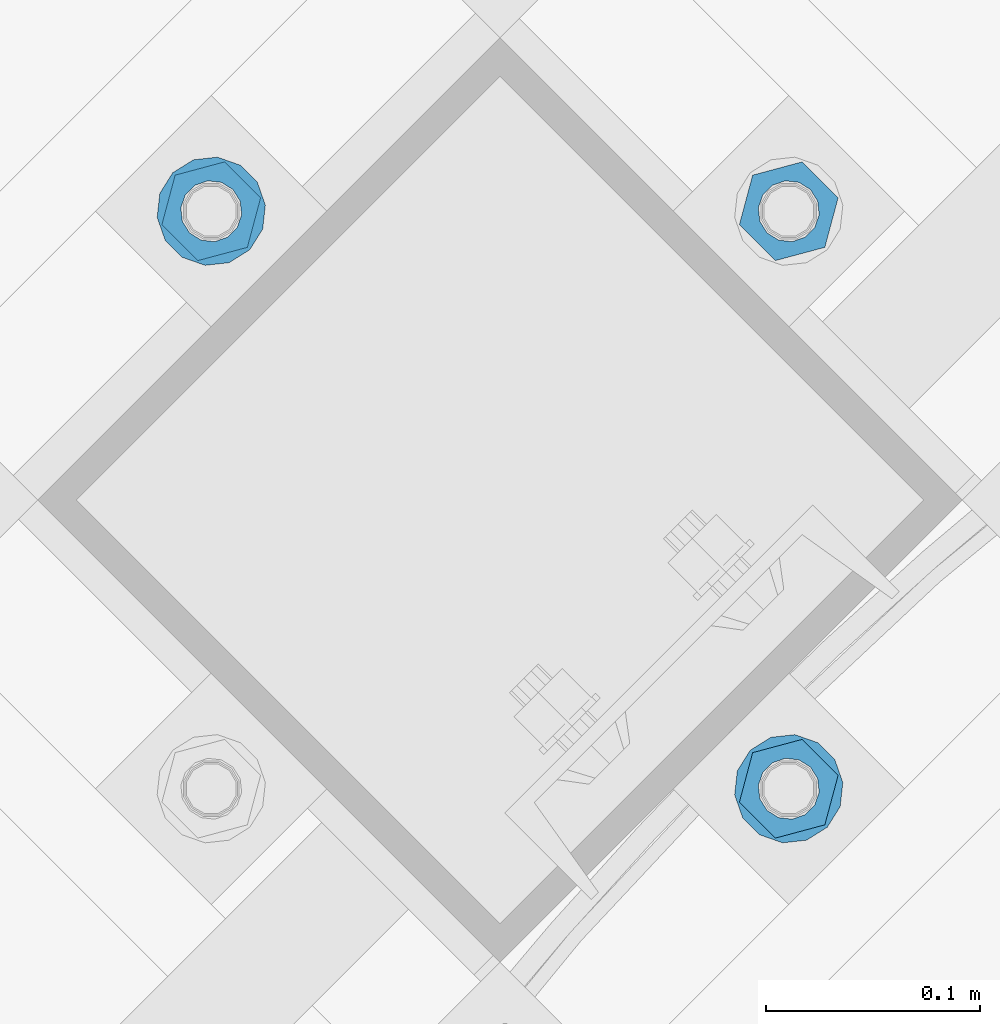
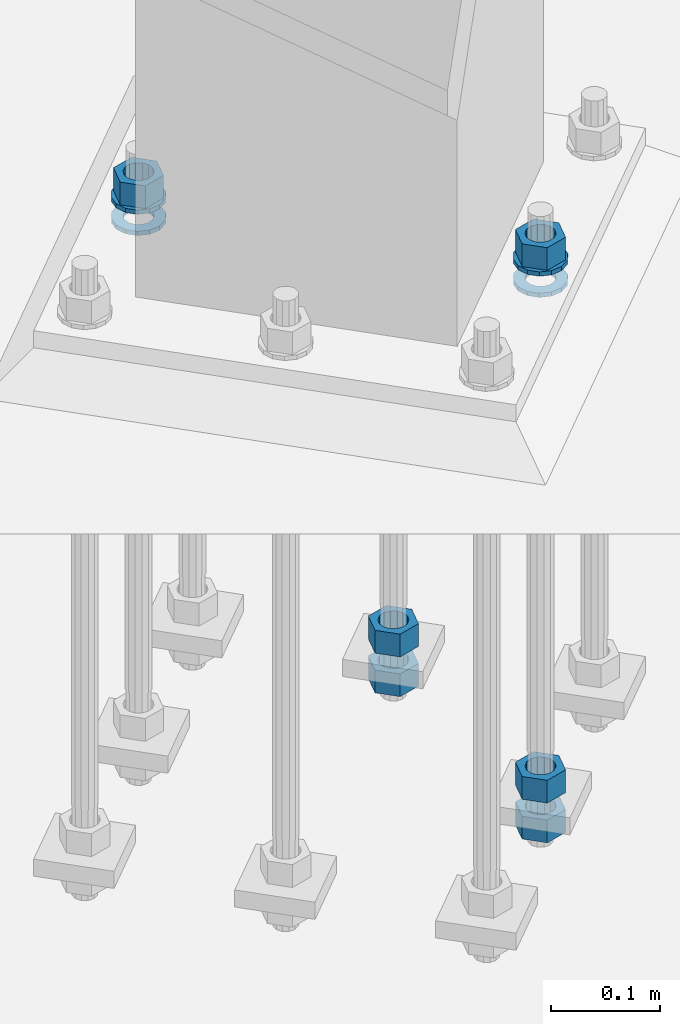
# One storey, part 871 of 1876: 10 columns, 1 element without a shape of its own.
"""IFC2X3 building model written with IfcOpenShell, lengths in millimetres."""

import ifcopenshell
import ifcopenshell.guid

model = None  # the IFC model being written
_history = None  # IfcOwnerHistory: only IFC2X3 demands one
_inside = {}  # id of a spatial element -> (the spatial element, [elements in it])
_under = {}  # id of a project, library or spatial element -> (it, [spatial elements below it])
_declared = {}  # id of a project -> (the project, [libraries it declares])
_typed = {}  # id of a type object -> (the type object, [elements of that type])
_made_of = {}  # id of a material, layer set ... -> (it, [elements and type objects made of it])


def new_model(schema):
    """Start an empty IFC model of exactly this schema.

    Asked for "IFC4X3", IfcOpenShell would pick the latest addendum, in which some entities
    have other attributes; the version numbers below select the first issue.
    IFC2X3 requires an IfcOwnerHistory on every rooted entity: one is made here for all.
    """
    global model, _history
    if schema == "IFC4X3":
        model = ifcopenshell.file(schema_version=(4, 3, 0, 0))
    else:
        model = ifcopenshell.file(schema=schema)
    _inside.clear()
    _under.clear()
    _declared.clear()
    _typed.clear()
    _made_of.clear()
    _history = None
    if model.schema == "IFC2X3":
        org = make("IfcOrganization", Name="unknown")
        user = make(
            "IfcPersonAndOrganization",
            ThePerson=make("IfcPerson", FamilyName="unknown"),
            TheOrganization=org,
        )
        app = make(
            "IfcApplication",
            ApplicationDeveloper=org,
            Version="unknown",
            ApplicationFullName="unknown",
            ApplicationIdentifier="unknown",
        )
        _history = make(
            "IfcOwnerHistory",
            OwningUser=user,
            OwningApplication=app,
            ChangeAction="ADDED",
            CreationDate=0,
        )
    return model


def make(cls, **values):
    """One entity of the class cls with the attributes given. An attribute that is None is left unset."""
    return model.create_entity(
        cls, **{name: value for name, value in values.items() if value is not None}
    )


def rooted(cls, **values):
    """An entity with a GlobalId (a new one), such as an element, a storey or a relation."""
    return make(cls, GlobalId=ifcopenshell.guid.new(), OwnerHistory=_history, **values)


def si_unit(unit_type, name, prefix=None):
    """IfcSIUnit, for example si_unit("LENGTHUNIT", "METRE", prefix="MILLI")."""
    return make("IfcSIUnit", UnitType=unit_type, Prefix=prefix, Name=name)


def assignment(units):
    """IfcUnitAssignment: the units of a project."""
    return None if units is None else make("IfcUnitAssignment", Units=units)


def point(xyz):
    """IfcCartesianPoint."""
    return None if xyz is None else make("IfcCartesianPoint", Coordinates=xyz)


def direction(xyz):
    """IfcDirection."""
    return None if xyz is None else make("IfcDirection", DirectionRatios=xyz)


def frame(location, z_axis=None, x_axis=None):
    """IfcAxis2Placement3D, a coordinate frame: its origin and axes. An axis left out is left unset."""
    return make(
        "IfcAxis2Placement3D",
        Location=point(location),
        Axis=direction(z_axis),
        RefDirection=direction(x_axis),
    )


def origin_with_axes():
    """The frame at (0, 0, 0) with the z axis (0, 0, 1) and the x axis (1, 0, 0) written out."""
    return frame((0.0, 0.0, 0.0), z_axis=(0.0, 0.0, 1.0), x_axis=(1.0, 0.0, 0.0))


def place(relative_to, where):
    """IfcLocalPlacement: puts the frame where relative to a parent placement (None: the world)."""
    return make(
        "IfcLocalPlacement", PlacementRelTo=relative_to, RelativePlacement=where
    )


def context(
    kind, dimensions, precision=None, world=None, true_north=None, identifier=None
):
    """IfcGeometricRepresentationContext, for example the 3D "Model" context."""
    return make(
        "IfcGeometricRepresentationContext",
        ContextIdentifier=identifier,
        ContextType=kind,
        CoordinateSpaceDimension=dimensions,
        Precision=precision,
        WorldCoordinateSystem=world,
        TrueNorth=true_north,
    )


def subcontext(parent, identifier, kind, view, scale=None):
    """IfcGeometricRepresentationSubContext, for example "Body" below "Model"."""
    return make(
        "IfcGeometricRepresentationSubContext",
        ContextIdentifier=identifier,
        ContextType=kind,
        ParentContext=parent,
        TargetScale=scale,
        TargetView=view,
    )


def project(units=None, contexts=None):
    """IfcProject with its units and contexts."""
    return rooted(
        "IfcProject",
        Name="project",
        RepresentationContexts=contexts,
        UnitsInContext=assignment(units),
    )


def spatial(cls, under=None, at=None, **own):
    """A site, building, storey or space (cls), placed at a placement, below another one or the project."""
    s = rooted(cls, ObjectPlacement=at, **own)
    if under is not None:
        _under.setdefault(under.id(), (under, []))[1].append(s)
    return s


def faces_of(points, faces, orient=None, outer=None):
    """IfcFace entities. A face is a list of loops; a loop is a list of indices into points, from 0.

    orient and outer hold one flag for each loop. By default every Orientation is true, the
    first loop of a face is its IfcFaceOuterBound and the others are IfcFaceBound.
    """
    made = []
    for i, loops in enumerate(faces):
        bounds = []
        for j, loop in enumerate(loops):
            is_outer = j == 0 if outer is None else outer[i][j]
            bounds.append(
                make(
                    "IfcFaceOuterBound" if is_outer else "IfcFaceBound",
                    Bound=make("IfcPolyLoop", Polygon=[points[k] for k in loop]),
                    Orientation=True if orient is None else orient[i][j],
                )
            )
        made.append(make("IfcFace", Bounds=bounds))
    return made


def faceted_brep(points, faces, orient=None, outer=None, voids=None):
    """IfcFacetedBrep: a solid bounded by flat faces; with voids (closed shells), ...WithVoids."""
    shared = [point(p) for p in points]
    hull = make("IfcClosedShell", CfsFaces=faces_of(shared, faces, orient, outer))
    if voids is None:
        return make("IfcFacetedBrep", Outer=hull)
    return make(
        "IfcFacetedBrepWithVoids",
        Outer=hull,
        Voids=[
            make(cls, CfsFaces=faces_of(shared, fs, o, b)) for cls, fs, o, b in voids
        ],
    )


def shape(context_of_items, identifier, shape_type, items):
    """IfcShapeRepresentation: the items that make up one representation, for example the "Body"."""
    return make(
        "IfcShapeRepresentation",
        ContextOfItems=context_of_items,
        RepresentationIdentifier=identifier,
        RepresentationType=shape_type,
        Items=items,
    )


def material(Name=None, Category=None):
    """IfcMaterial."""
    return make("IfcMaterial", Name=Name, Category=Category)


def made_of(thing, what):
    """Note that an element or type object is made of a material, layer set ...; save() writes the relation."""
    if what is not None:
        _made_of.setdefault(what.id(), (what, []))[1].append(thing)
    return thing


def type_object(cls, material=None, **own):
    """A type object (cls), such as IfcWallType, which elements share."""
    return made_of(rooted(cls, **own), material)


def element(
    cls,
    number,
    at=None,
    inside=None,
    cuts=None,
    type_object=None,
    material=None,
    context=None,
    identifier="Body",
    shape_type=None,
    held_by="IfcProductDefinitionShape",
    body=None,
    shapes=None,
    **own,
):
    """One element of the class cls, such as IfcWall. Its Tag is "e" and its number.

    at: its placement. inside: the storey or other place that contains it. cuts: it is an
    opening in that element (IfcRelVoidsElement). A single representation is given by context,
    identifier, shape_type and body (its items); several are given by shapes. held_by: the class
    of the entity that holds the representations. save() writes the other relations.
    """
    e = rooted(cls, Tag="e%d" % number, ObjectPlacement=at, **own)
    if body is not None:
        shapes = [shape(context, identifier, shape_type, body)]
    if shapes is not None:
        e.Representation = make(held_by, Representations=shapes)
    if inside is not None:
        _inside.setdefault(inside.id(), (inside, []))[1].append(e)
    if cuts is not None:
        rooted(
            "IfcRelVoidsElement", RelatingBuildingElement=cuts, RelatedOpeningElement=e
        )
    if type_object is not None:
        _typed.setdefault(type_object.id(), (type_object, []))[1].append(e)
    return made_of(e, material)


def aggregate(whole, parts):
    """IfcRelAggregates: a whole, such as a stair, and the parts it consists of."""
    return rooted("IfcRelAggregates", RelatingObject=whole, RelatedObjects=parts)


def save(model, path):
    """Write the relations noted so far, then the file.

    IfcRelAggregates (storeys below a building ...), IfcRelContainedInSpatialStructure (elements
    in a storey), IfcRelDefinesByType, IfcRelAssociatesMaterial and IfcRelDeclares: one each for
    every whole, place, type object, material and project.
    """
    for whole, parts in _under.values():
        aggregate(whole, parts)
    for where, things in _inside.values():
        rooted(
            "IfcRelContainedInSpatialStructure",
            RelatedElements=things,
            RelatingStructure=where,
        )
    for kind, things in _typed.values():
        rooted("IfcRelDefinesByType", RelatedObjects=things, RelatingType=kind)
    for what, things in _made_of.values():
        rooted("IfcRelAssociatesMaterial", RelatedObjects=things, RelatingMaterial=what)
    for by, libraries in _declared.values():
        rooted("IfcRelDeclares", RelatingContext=by, RelatedDefinitions=libraries)
    model.write(path)


model = new_model("IFC2X3")

# Units and contexts
model_context = context("Model", 3, precision=1e-05, world=origin_with_axes())
body_context = subcontext(model_context, "Body", "Model", "MODEL_VIEW")
ifc_project = project(units=[si_unit("LENGTHUNIT", "METRE", prefix="MILLI"), si_unit("AREAUNIT", "SQUARE_METRE"), si_unit("VOLUMEUNIT", "CUBIC_METRE"), si_unit("MASSUNIT", "GRAM", prefix="KILO"), si_unit("TIMEUNIT", "SECOND"), si_unit("PLANEANGLEUNIT", "RADIAN"), si_unit("SOLIDANGLEUNIT", "STERADIAN"), si_unit("THERMODYNAMICTEMPERATUREUNIT", "DEGREE_CELSIUS"), si_unit("LUMINOUSINTENSITYUNIT", "LUMEN")], contexts=[model_context])

# Site, building, storey
site_placement = place(None, origin_with_axes())
site = spatial("IfcSite", under=ifc_project, at=site_placement, CompositionType="ELEMENT")
building_placement = place(site_placement, origin_with_axes())
building = spatial("IfcBuilding", under=site, at=building_placement, Name="Undefined", CompositionType="ELEMENT")
storey_placement = place(building_placement, origin_with_axes())
storey = spatial("IfcBuildingStorey", under=building, at=storey_placement, Name="Undefined", CompositionType="ELEMENT", Elevation=0.0)

# Assembly, columns
assembly_placement = place(storey_placement, origin_with_axes())
assembly = element("IfcElementAssembly", 1, at=assembly_placement, inside=storey, Name="TEMPLATE", AssemblyPlace="NOTDEFINED", PredefinedType="RIGID_FRAME")
ifc_material_1 = material(Name="STEEL/A563")
column_type_1 = type_object("IfcColumnType", Name="1_HEAVY_HEX_NUT", PredefinedType="NOTDEFINED")
column_1_placement = place(assembly_placement, frame((3917.71672118143, -12055.5665371028, -508.0), z_axis=(0.707106781186548, 0.707106781186547, 0.0), x_axis=(0.0, 0.0, -1.0)))
column_1 = element("IfcColumn", 2, at=column_1_placement, type_object=column_type_1, material=ifc_material_1, Name="NUT", ObjectType="1_HEAVY_HEX_NUT", context=body_context, shape_type="Brep", body=[
    faceted_brep([(0.0, -23.8099994659442, 9.09494701772928e-13), (0.0, -11.9099998474121, -20.6200008392352), (25.4, -11.9099998474157, -20.6200008392361), (25.4, -23.8099994659478, 0.0), (0.0, 11.9099998474157, -20.620000839237), (25.4, 11.9099998474121, -20.620000839237), (0.0, 23.8099994659478, 9.09494701772928e-13), (25.4, 23.8099994659442, 0.0), (0.0, 11.9099998474157, 20.620000839237), (25.4, 11.9099998474121, 20.620000839237), (0.0, -11.9099998474121, 20.6200008392389), (25.4, -11.9099998474157, 20.6200008392379), (0.0, 1.81898940354586e-12, 14.2899999618567), (0.0, 6.20019861543915, 12.8748450879584), (25.4, 6.20019861543733, 12.8748450879593), (25.4, 0.0, 14.2899999618558), (0.0, 11.1723718546473, 8.90966924477925), (25.4, 11.1723718546436, 8.90966924477925), (0.0, 13.9317198278914, 3.17982413774916), (25.4, 13.9317198278877, 3.17982413775007), (0.0, 13.9317198278914, -3.17982413774644), (25.4, 13.9317198278895, -3.17982413774735), (0.0, 11.1723718546473, -8.90966924477834), (25.4, 11.1723718546455, -8.90966924477925), (0.0, 6.20019861544279, -12.8748450879575), (25.4, 6.20019861543915, -12.8748450879584), (0.0, 3.63797880709171e-12, -14.2899999618548), (25.4, -3.63797880709171e-12, -14.2899999618548), (0.0, -6.20019861543733, -12.8748450879566), (25.4, -6.20019861544097, -12.8748450879584), (0.0, -11.1723718546455, -8.90966924477743), (25.4, -11.1723718546473, -8.90966924477834), (0.0, -13.9317198278877, -3.17982413774735), (25.4, -13.9317198278914, -3.17982413774826), (0.0, -13.9317198278895, 3.17982413774735), (25.4, -13.9317198278914, 3.17982413774826), (0.0, -11.1723718546455, 8.90966924477925), (25.4, -11.1723718546473, 8.90966924478016), (0.0, -6.20019861543915, 12.8748450879593), (25.4, -6.20019861544279, 12.8748450879593)], [[[0, 1, 2, 3]], [[1, 4, 5, 2]], [[4, 6, 7, 5]], [[6, 8, 9, 7]], [[8, 10, 11, 9]], [[10, 0, 3, 11]], [[12, 13, 14, 15]], [[13, 16, 17, 14]], [[16, 18, 19, 17]], [[18, 20, 21, 19]], [[20, 22, 23, 21]], [[22, 24, 25, 23]], [[24, 26, 27, 25]], [[26, 28, 29, 27]], [[28, 30, 31, 29]], [[30, 32, 33, 31]], [[32, 34, 35, 33]], [[34, 36, 37, 35]], [[36, 38, 39, 37]], [[38, 12, 15, 39]], [[5, 7, 9, 11, 3, 2], [17, 19, 21, 23, 25, 27, 29, 31, 33, 35, 37, 39, 15, 14]], [[10, 8, 6, 4, 1, 0], [38, 36, 34, 32, 30, 28, 26, 24, 22, 20, 18, 16, 13, 12]]]),
])
column_2_placement = place(assembly_placement, frame((3917.71672118143, -12055.5665371028, -552.45), z_axis=(0.707106781186548, 0.707106781186547, 0.0), x_axis=(0.0, 0.0, -1.0)))
column_2 = element("IfcColumn", 3, at=column_2_placement, type_object=column_type_1, material=ifc_material_1, Name="NUT", ObjectType="1_HEAVY_HEX_NUT", context=body_context, shape_type="Brep", body=[
    faceted_brep([(0.0, -23.8099994659442, 9.09494701772928e-13), (0.0, -11.9099998474121, -20.6200008392352), (25.4, -11.9099998474157, -20.6200008392361), (25.4, -23.8099994659478, 0.0), (0.0, 11.9099998474157, -20.620000839237), (25.4, 11.9099998474121, -20.620000839237), (0.0, 23.8099994659478, 9.09494701772928e-13), (25.4, 23.8099994659442, 0.0), (0.0, 11.9099998474157, 20.620000839237), (25.4, 11.9099998474121, 20.620000839237), (0.0, -11.9099998474121, 20.6200008392389), (25.4, -11.9099998474157, 20.6200008392379), (0.0, 1.81898940354586e-12, 14.2899999618567), (0.0, 6.20019861543915, 12.8748450879584), (25.4, 6.20019861543733, 12.8748450879593), (25.4, 0.0, 14.2899999618558), (0.0, 11.1723718546473, 8.90966924477925), (25.4, 11.1723718546436, 8.90966924477925), (0.0, 13.9317198278914, 3.17982413774916), (25.4, 13.9317198278877, 3.17982413775007), (0.0, 13.9317198278914, -3.17982413774644), (25.4, 13.9317198278895, -3.17982413774735), (0.0, 11.1723718546473, -8.90966924477834), (25.4, 11.1723718546455, -8.90966924477925), (0.0, 6.20019861544279, -12.8748450879575), (25.4, 6.20019861543915, -12.8748450879584), (0.0, 3.63797880709171e-12, -14.2899999618548), (25.4, -3.63797880709171e-12, -14.2899999618548), (0.0, -6.20019861543733, -12.8748450879566), (25.4, -6.20019861544097, -12.8748450879584), (0.0, -11.1723718546455, -8.90966924477743), (25.4, -11.1723718546473, -8.90966924477834), (0.0, -13.9317198278877, -3.17982413774735), (25.4, -13.9317198278914, -3.17982413774826), (0.0, -13.9317198278895, 3.17982413774735), (25.4, -13.9317198278914, 3.17982413774826), (0.0, -11.1723718546455, 8.90966924477925), (25.4, -11.1723718546473, 8.90966924478016), (0.0, -6.20019861543915, 12.8748450879593), (25.4, -6.20019861544279, 12.8748450879593)], [[[0, 1, 2, 3]], [[1, 4, 5, 2]], [[4, 6, 7, 5]], [[6, 8, 9, 7]], [[8, 10, 11, 9]], [[10, 0, 3, 11]], [[12, 13, 14, 15]], [[13, 16, 17, 14]], [[16, 18, 19, 17]], [[18, 20, 21, 19]], [[20, 22, 23, 21]], [[22, 24, 25, 23]], [[24, 26, 27, 25]], [[26, 28, 29, 27]], [[28, 30, 31, 29]], [[30, 32, 33, 31]], [[32, 34, 35, 33]], [[34, 36, 37, 35]], [[36, 38, 39, 37]], [[38, 12, 15, 39]], [[5, 7, 9, 11, 3, 2], [17, 19, 21, 23, 25, 27, 29, 31, 33, 35, 37, 39, 15, 14]], [[10, 8, 6, 4, 1, 0], [38, 36, 34, 32, 30, 28, 26, 24, 22, 20, 18, 16, 13, 12]]]),
])
column_3_placement = place(assembly_placement, frame((3917.71672118143, -12324.9742207351, 87.3125), z_axis=(0.707106781186548, 0.707106781186547, 0.0), x_axis=(0.0, 0.0, -1.0)))
column_3 = element("IfcColumn", 4, at=column_3_placement, type_object=column_type_1, material=ifc_material_1, Name="NUT", ObjectType="1_HEAVY_HEX_NUT", context=body_context, shape_type="Brep", body=[
    faceted_brep([(0.0, -23.8099994659442, 9.09494701772928e-13), (0.0, -11.9099998474121, -20.6200008392352), (25.4, -11.9099998474157, -20.6200008392361), (25.4, -23.8099994659478, 0.0), (0.0, 11.9099998474157, -20.620000839237), (25.4, 11.9099998474121, -20.620000839237), (0.0, 23.8099994659478, 9.09494701772928e-13), (25.4, 23.8099994659442, 0.0), (0.0, 11.9099998474157, 20.620000839237), (25.4, 11.9099998474121, 20.620000839237), (0.0, -11.9099998474121, 20.6200008392389), (25.4, -11.9099998474157, 20.6200008392379), (0.0, 1.81898940354586e-12, 14.2899999618567), (0.0, 6.20019861543915, 12.8748450879584), (25.4, 6.20019861543733, 12.8748450879593), (25.4, 0.0, 14.2899999618558), (0.0, 11.1723718546473, 8.90966924477925), (25.4, 11.1723718546436, 8.90966924477925), (0.0, 13.9317198278914, 3.17982413774916), (25.4, 13.9317198278877, 3.17982413775007), (0.0, 13.9317198278914, -3.17982413774644), (25.4, 13.9317198278895, -3.17982413774735), (0.0, 11.1723718546473, -8.90966924477834), (25.4, 11.1723718546455, -8.90966924477925), (0.0, 6.20019861544279, -12.8748450879575), (25.4, 6.20019861543915, -12.8748450879584), (0.0, 3.63797880709171e-12, -14.2899999618548), (25.4, -3.63797880709171e-12, -14.2899999618548), (0.0, -6.20019861543733, -12.8748450879566), (25.4, -6.20019861544097, -12.8748450879584), (0.0, -11.1723718546455, -8.90966924477743), (25.4, -11.1723718546473, -8.90966924477834), (0.0, -13.9317198278877, -3.17982413774735), (25.4, -13.9317198278914, -3.17982413774826), (0.0, -13.9317198278895, 3.17982413774735), (25.4, -13.9317198278914, 3.17982413774826), (0.0, -11.1723718546455, 8.90966924477925), (25.4, -11.1723718546473, 8.90966924478016), (0.0, -6.20019861543915, 12.8748450879593), (25.4, -6.20019861544279, 12.8748450879593)], [[[0, 1, 2, 3]], [[1, 4, 5, 2]], [[4, 6, 7, 5]], [[6, 8, 9, 7]], [[8, 10, 11, 9]], [[10, 0, 3, 11]], [[12, 13, 14, 15]], [[13, 16, 17, 14]], [[16, 18, 19, 17]], [[18, 20, 21, 19]], [[20, 22, 23, 21]], [[22, 24, 25, 23]], [[24, 26, 27, 25]], [[26, 28, 29, 27]], [[28, 30, 31, 29]], [[30, 32, 33, 31]], [[32, 34, 35, 33]], [[34, 36, 37, 35]], [[36, 38, 39, 37]], [[38, 12, 15, 39]], [[5, 7, 9, 11, 3, 2], [17, 19, 21, 23, 25, 27, 29, 31, 33, 35, 37, 39, 15, 14]], [[10, 8, 6, 4, 1, 0], [38, 36, 34, 32, 30, 28, 26, 24, 22, 20, 18, 16, 13, 12]]]),
])
column_4_placement = place(assembly_placement, frame((3917.71672118143, -12324.9742207351, -508.0), z_axis=(0.707106781186548, 0.707106781186547, 0.0), x_axis=(0.0, 0.0, -1.0)))
column_4 = element("IfcColumn", 5, at=column_4_placement, type_object=column_type_1, material=ifc_material_1, Name="NUT", ObjectType="1_HEAVY_HEX_NUT", context=body_context, shape_type="Brep", body=[
    faceted_brep([(0.0, -23.8099994659442, 9.09494701772928e-13), (0.0, -11.9099998474121, -20.6200008392352), (25.4, -11.9099998474157, -20.6200008392361), (25.4, -23.8099994659478, 0.0), (0.0, 11.9099998474157, -20.620000839237), (25.4, 11.9099998474121, -20.620000839237), (0.0, 23.8099994659478, 9.09494701772928e-13), (25.4, 23.8099994659442, 0.0), (0.0, 11.9099998474157, 20.620000839237), (25.4, 11.9099998474121, 20.620000839237), (0.0, -11.9099998474121, 20.6200008392389), (25.4, -11.9099998474157, 20.6200008392379), (0.0, 1.81898940354586e-12, 14.2899999618567), (0.0, 6.20019861543915, 12.8748450879584), (25.4, 6.20019861543733, 12.8748450879593), (25.4, 0.0, 14.2899999618558), (0.0, 11.1723718546473, 8.90966924477925), (25.4, 11.1723718546436, 8.90966924477925), (0.0, 13.9317198278914, 3.17982413774916), (25.4, 13.9317198278877, 3.17982413775007), (0.0, 13.9317198278914, -3.17982413774644), (25.4, 13.9317198278895, -3.17982413774735), (0.0, 11.1723718546473, -8.90966924477834), (25.4, 11.1723718546455, -8.90966924477925), (0.0, 6.20019861544279, -12.8748450879575), (25.4, 6.20019861543915, -12.8748450879584), (0.0, 3.63797880709171e-12, -14.2899999618548), (25.4, -3.63797880709171e-12, -14.2899999618548), (0.0, -6.20019861543733, -12.8748450879566), (25.4, -6.20019861544097, -12.8748450879584), (0.0, -11.1723718546455, -8.90966924477743), (25.4, -11.1723718546473, -8.90966924477834), (0.0, -13.9317198278877, -3.17982413774735), (25.4, -13.9317198278914, -3.17982413774826), (0.0, -13.9317198278895, 3.17982413774735), (25.4, -13.9317198278914, 3.17982413774826), (0.0, -11.1723718546455, 8.90966924477925), (25.4, -11.1723718546473, 8.90966924478016), (0.0, -6.20019861543915, 12.8748450879593), (25.4, -6.20019861544279, 12.8748450879593)], [[[0, 1, 2, 3]], [[1, 4, 5, 2]], [[4, 6, 7, 5]], [[6, 8, 9, 7]], [[8, 10, 11, 9]], [[10, 0, 3, 11]], [[12, 13, 14, 15]], [[13, 16, 17, 14]], [[16, 18, 19, 17]], [[18, 20, 21, 19]], [[20, 22, 23, 21]], [[22, 24, 25, 23]], [[24, 26, 27, 25]], [[26, 28, 29, 27]], [[28, 30, 31, 29]], [[30, 32, 33, 31]], [[32, 34, 35, 33]], [[34, 36, 37, 35]], [[36, 38, 39, 37]], [[38, 12, 15, 39]], [[5, 7, 9, 11, 3, 2], [17, 19, 21, 23, 25, 27, 29, 31, 33, 35, 37, 39, 15, 14]], [[10, 8, 6, 4, 1, 0], [38, 36, 34, 32, 30, 28, 26, 24, 22, 20, 18, 16, 13, 12]]]),
])
column_5_placement = place(assembly_placement, frame((3917.71672118143, -12324.9742207351, -552.45), z_axis=(0.707106781186548, 0.707106781186547, 0.0), x_axis=(0.0, 0.0, -1.0)))
column_5 = element("IfcColumn", 6, at=column_5_placement, type_object=column_type_1, material=ifc_material_1, Name="NUT", ObjectType="1_HEAVY_HEX_NUT", context=body_context, shape_type="Brep", body=[
    faceted_brep([(0.0, -23.8099994659442, 9.09494701772928e-13), (0.0, -11.9099998474121, -20.6200008392352), (25.4, -11.9099998474157, -20.6200008392361), (25.4, -23.8099994659478, 0.0), (0.0, 11.9099998474157, -20.620000839237), (25.4, 11.9099998474121, -20.620000839237), (0.0, 23.8099994659478, 9.09494701772928e-13), (25.4, 23.8099994659442, 0.0), (0.0, 11.9099998474157, 20.620000839237), (25.4, 11.9099998474121, 20.620000839237), (0.0, -11.9099998474121, 20.6200008392389), (25.4, -11.9099998474157, 20.6200008392379), (0.0, 1.81898940354586e-12, 14.2899999618567), (0.0, 6.20019861543915, 12.8748450879584), (25.4, 6.20019861543733, 12.8748450879593), (25.4, 0.0, 14.2899999618558), (0.0, 11.1723718546473, 8.90966924477925), (25.4, 11.1723718546436, 8.90966924477925), (0.0, 13.9317198278914, 3.17982413774916), (25.4, 13.9317198278877, 3.17982413775007), (0.0, 13.9317198278914, -3.17982413774644), (25.4, 13.9317198278895, -3.17982413774735), (0.0, 11.1723718546473, -8.90966924477834), (25.4, 11.1723718546455, -8.90966924477925), (0.0, 6.20019861544279, -12.8748450879575), (25.4, 6.20019861543915, -12.8748450879584), (0.0, 3.63797880709171e-12, -14.2899999618548), (25.4, -3.63797880709171e-12, -14.2899999618548), (0.0, -6.20019861543733, -12.8748450879566), (25.4, -6.20019861544097, -12.8748450879584), (0.0, -11.1723718546455, -8.90966924477743), (25.4, -11.1723718546473, -8.90966924477834), (0.0, -13.9317198278877, -3.17982413774735), (25.4, -13.9317198278914, -3.17982413774826), (0.0, -13.9317198278895, 3.17982413774735), (25.4, -13.9317198278914, 3.17982413774826), (0.0, -11.1723718546455, 8.90966924477925), (25.4, -11.1723718546473, 8.90966924478016), (0.0, -6.20019861543915, 12.8748450879593), (25.4, -6.20019861544279, 12.8748450879593)], [[[0, 1, 2, 3]], [[1, 4, 5, 2]], [[4, 6, 7, 5]], [[6, 8, 9, 7]], [[8, 10, 11, 9]], [[10, 0, 3, 11]], [[12, 13, 14, 15]], [[13, 16, 17, 14]], [[16, 18, 19, 17]], [[18, 20, 21, 19]], [[20, 22, 23, 21]], [[22, 24, 25, 23]], [[24, 26, 27, 25]], [[26, 28, 29, 27]], [[28, 30, 31, 29]], [[30, 32, 33, 31]], [[32, 34, 35, 33]], [[34, 36, 37, 35]], [[36, 38, 39, 37]], [[38, 12, 15, 39]], [[5, 7, 9, 11, 3, 2], [17, 19, 21, 23, 25, 27, 29, 31, 33, 35, 37, 39, 15, 14]], [[10, 8, 6, 4, 1, 0], [38, 36, 34, 32, 30, 28, 26, 24, 22, 20, 18, 16, 13, 12]]]),
])
column_6_placement = place(assembly_placement, frame((3648.30903754913, -12055.5665371028, 87.3125), z_axis=(-0.707106781186547, -0.707106781186548, 0.0), x_axis=(0.0, 0.0, -1.0)))
column_6 = element("IfcColumn", 7, at=column_6_placement, type_object=column_type_1, material=ifc_material_1, Name="NUT", ObjectType="1_HEAVY_HEX_NUT", context=body_context, shape_type="Brep", body=[
    faceted_brep([(0.0, -23.8099994659442, 9.09494701772928e-13), (0.0, -11.9099998474121, -20.6200008392352), (25.4, -11.9099998474157, -20.6200008392361), (25.4, -23.8099994659478, 0.0), (0.0, 11.9099998474157, -20.620000839237), (25.4, 11.9099998474121, -20.620000839237), (0.0, 23.8099994659478, 9.09494701772928e-13), (25.4, 23.8099994659442, 0.0), (0.0, 11.9099998474157, 20.620000839237), (25.4, 11.9099998474121, 20.620000839237), (0.0, -11.9099998474121, 20.6200008392389), (25.4, -11.9099998474157, 20.6200008392379), (0.0, 1.81898940354586e-12, 14.2899999618567), (0.0, 6.20019861543915, 12.8748450879584), (25.4, 6.20019861543733, 12.8748450879593), (25.4, 0.0, 14.2899999618558), (0.0, 11.1723718546473, 8.90966924477925), (25.4, 11.1723718546436, 8.90966924477925), (0.0, 13.9317198278914, 3.17982413774916), (25.4, 13.9317198278877, 3.17982413775007), (0.0, 13.9317198278914, -3.17982413774644), (25.4, 13.9317198278895, -3.17982413774735), (0.0, 11.1723718546473, -8.90966924477834), (25.4, 11.1723718546455, -8.90966924477925), (0.0, 6.20019861544279, -12.8748450879575), (25.4, 6.20019861543915, -12.8748450879584), (0.0, 3.63797880709171e-12, -14.2899999618548), (25.4, -3.63797880709171e-12, -14.2899999618548), (0.0, -6.20019861543733, -12.8748450879566), (25.4, -6.20019861544097, -12.8748450879584), (0.0, -11.1723718546455, -8.90966924477743), (25.4, -11.1723718546473, -8.90966924477834), (0.0, -13.9317198278877, -3.17982413774735), (25.4, -13.9317198278914, -3.17982413774826), (0.0, -13.9317198278895, 3.17982413774735), (25.4, -13.9317198278914, 3.17982413774826), (0.0, -11.1723718546455, 8.90966924477925), (25.4, -11.1723718546473, 8.90966924478016), (0.0, -6.20019861543915, 12.8748450879593), (25.4, -6.20019861544279, 12.8748450879593)], [[[0, 1, 2, 3]], [[1, 4, 5, 2]], [[4, 6, 7, 5]], [[6, 8, 9, 7]], [[8, 10, 11, 9]], [[10, 0, 3, 11]], [[12, 13, 14, 15]], [[13, 16, 17, 14]], [[16, 18, 19, 17]], [[18, 20, 21, 19]], [[20, 22, 23, 21]], [[22, 24, 25, 23]], [[24, 26, 27, 25]], [[26, 28, 29, 27]], [[28, 30, 31, 29]], [[30, 32, 33, 31]], [[32, 34, 35, 33]], [[34, 36, 37, 35]], [[36, 38, 39, 37]], [[38, 12, 15, 39]], [[5, 7, 9, 11, 3, 2], [17, 19, 21, 23, 25, 27, 29, 31, 33, 35, 37, 39, 15, 14]], [[10, 8, 6, 4, 1, 0], [38, 36, 34, 32, 30, 28, 26, 24, 22, 20, 18, 16, 13, 12]]]),
])
ifc_material_2 = material(Name="STEEL/F436")
column_type_2 = type_object("IfcColumnType", Name="1_WASHER", PredefinedType="NOTDEFINED")
column_7_placement = place(assembly_placement, frame((3917.71672118143, -12324.9742207351, 38.1), z_axis=(0.707106781186548, 0.707106781186547, 0.0), x_axis=(0.0, 0.0, -1.0)))
column_7 = element("IfcColumn", 8, at=column_7_placement, type_object=column_type_2, material=ifc_material_2, Name="WASHER", ObjectType="1_WASHER", context=body_context, shape_type="Brep", body=[
    faceted_brep([(0.0, -25.3999996185375, 0.0), (0.0, -22.8846089010331, -11.0206468080742), (4.7625, -22.8846089010331, -11.0206468080742), (4.7625, -25.3999996185375, 0.0), (0.0, -15.8366407293743, -19.8585193564477), (4.7625, -15.8366407293743, -19.8585193564477), (0.0, -5.65203163760816, -24.7631685975166), (4.7625, -5.65203163760816, -24.7631685975166), (0.0, 5.65203163760452, -24.7631685975166), (4.7625, 5.65203163760452, -24.7631685975166), (0.0, 15.8366407293706, -19.858519356445), (4.7625, 15.8366407293706, -19.858519356445), (0.0, 22.8846089010331, -11.0206468080733), (4.7625, 22.8846089010331, -11.0206468080733), (0.0, 25.3999996185339, 9.09494701772928e-13), (4.7625, 25.3999996185339, 9.09494701772928e-13), (0.0, 22.8846089010331, 11.0206468080751), (4.7625, 22.8846089010331, 11.0206468080751), (0.0, 15.8366407293706, 19.8585193564486), (4.7625, 15.8366407293706, 19.8585193564486), (0.0, 5.65203163760452, 24.7631685975175), (4.7625, 5.65203163760452, 24.7631685975175), (0.0, -5.65203163760816, 24.7631685975175), (4.7625, -5.65203163760816, 24.7631685975175), (0.0, -15.8366407293724, 19.8585193564459), (4.7625, -15.8366407293724, 19.8585193564459), (0.0, -22.8846089010367, 11.0206468080751), (4.7625, -22.8846089010367, 11.0206468080751), (0.0, 1.81898940354586e-12, 14.2899999618567), (0.0, 6.20019861543915, 12.8748450879584), (4.7625, 6.20019861543733, 12.8748450879593), (4.7625, 0.0, 14.2899999618558), (0.0, 11.1723718546473, 8.90966924477925), (4.7625, 11.1723718546436, 8.90966924477925), (0.0, 13.9317198278914, 3.17982413774916), (4.7625, 13.9317198278877, 3.17982413775007), (0.0, 13.9317198278914, -3.17982413774644), (4.7625, 13.9317198278895, -3.17982413774735), (0.0, 11.1723718546473, -8.90966924477834), (4.7625, 11.1723718546455, -8.90966924477925), (0.0, 6.20019861544279, -12.8748450879575), (4.7625, 6.20019861543915, -12.8748450879584), (0.0, 3.63797880709171e-12, -14.2899999618548), (4.7625, -3.63797880709171e-12, -14.2899999618548), (0.0, -6.20019861543733, -12.8748450879566), (4.7625, -6.20019861544097, -12.8748450879584), (0.0, -11.1723718546455, -8.90966924477743), (4.7625, -11.1723718546473, -8.90966924477834), (0.0, -13.9317198278877, -3.17982413774735), (4.7625, -13.9317198278914, -3.17982413774826), (0.0, -13.9317198278895, 3.17982413774735), (4.7625, -13.9317198278914, 3.17982413774826), (0.0, -11.1723718546455, 8.90966924477925), (4.7625, -11.1723718546473, 8.90966924478016), (0.0, -6.20019861543915, 12.8748450879593), (4.7625, -6.20019861544279, 12.8748450879593)], [[[0, 1, 2, 3]], [[1, 4, 5, 2]], [[4, 6, 7, 5]], [[6, 8, 9, 7]], [[8, 10, 11, 9]], [[10, 12, 13, 11]], [[12, 14, 15, 13]], [[14, 16, 17, 15]], [[16, 18, 19, 17]], [[18, 20, 21, 19]], [[20, 22, 23, 21]], [[22, 24, 25, 23]], [[24, 26, 27, 25]], [[26, 0, 3, 27]], [[28, 29, 30, 31]], [[29, 32, 33, 30]], [[32, 34, 35, 33]], [[34, 36, 37, 35]], [[36, 38, 39, 37]], [[38, 40, 41, 39]], [[40, 42, 43, 41]], [[42, 44, 45, 43]], [[44, 46, 47, 45]], [[46, 48, 49, 47]], [[48, 50, 51, 49]], [[50, 52, 53, 51]], [[52, 54, 55, 53]], [[54, 28, 31, 55]], [[5, 7, 9, 11, 13, 15, 17, 19, 21, 23, 25, 27, 3, 2], [33, 35, 37, 39, 41, 43, 45, 47, 49, 51, 53, 55, 31, 30]], [[26, 24, 22, 20, 18, 16, 14, 12, 10, 8, 6, 4, 1, 0], [54, 52, 50, 48, 46, 44, 42, 40, 38, 36, 34, 32, 29, 28]]]),
])
column_8_placement = place(assembly_placement, frame((3917.71672118143, -12324.9742207351, 61.9125), z_axis=(0.707106781186548, 0.707106781186547, 0.0), x_axis=(0.0, 0.0, -1.0)))
column_8 = element("IfcColumn", 9, at=column_8_placement, type_object=column_type_2, material=ifc_material_2, Name="WASHER", ObjectType="1_WASHER", context=body_context, shape_type="Brep", body=[
    faceted_brep([(0.0, -25.3999996185375, 0.0), (0.0, -22.8846089010331, -11.0206468080742), (4.7625, -22.8846089010331, -11.0206468080742), (4.7625, -25.3999996185375, 0.0), (0.0, -15.8366407293743, -19.8585193564477), (4.7625, -15.8366407293743, -19.8585193564477), (0.0, -5.65203163760816, -24.7631685975166), (4.7625, -5.65203163760816, -24.7631685975166), (0.0, 5.65203163760452, -24.7631685975166), (4.7625, 5.65203163760452, -24.7631685975166), (0.0, 15.8366407293706, -19.858519356445), (4.7625, 15.8366407293706, -19.858519356445), (0.0, 22.8846089010331, -11.0206468080733), (4.7625, 22.8846089010331, -11.0206468080733), (0.0, 25.3999996185339, 9.09494701772928e-13), (4.7625, 25.3999996185339, 9.09494701772928e-13), (0.0, 22.8846089010331, 11.0206468080751), (4.7625, 22.8846089010331, 11.0206468080751), (0.0, 15.8366407293706, 19.8585193564486), (4.7625, 15.8366407293706, 19.8585193564486), (0.0, 5.65203163760452, 24.7631685975175), (4.7625, 5.65203163760452, 24.7631685975175), (0.0, -5.65203163760816, 24.7631685975175), (4.7625, -5.65203163760816, 24.7631685975175), (0.0, -15.8366407293724, 19.8585193564459), (4.7625, -15.8366407293724, 19.8585193564459), (0.0, -22.8846089010367, 11.0206468080751), (4.7625, -22.8846089010367, 11.0206468080751), (0.0, 1.81898940354586e-12, 14.2899999618567), (0.0, 6.20019861543915, 12.8748450879584), (4.7625, 6.20019861543733, 12.8748450879593), (4.7625, 0.0, 14.2899999618558), (0.0, 11.1723718546473, 8.90966924477925), (4.7625, 11.1723718546436, 8.90966924477925), (0.0, 13.9317198278914, 3.17982413774916), (4.7625, 13.9317198278877, 3.17982413775007), (0.0, 13.9317198278914, -3.17982413774644), (4.7625, 13.9317198278895, -3.17982413774735), (0.0, 11.1723718546473, -8.90966924477834), (4.7625, 11.1723718546455, -8.90966924477925), (0.0, 6.20019861544279, -12.8748450879575), (4.7625, 6.20019861543915, -12.8748450879584), (0.0, 3.63797880709171e-12, -14.2899999618548), (4.7625, -3.63797880709171e-12, -14.2899999618548), (0.0, -6.20019861543733, -12.8748450879566), (4.7625, -6.20019861544097, -12.8748450879584), (0.0, -11.1723718546455, -8.90966924477743), (4.7625, -11.1723718546473, -8.90966924477834), (0.0, -13.9317198278877, -3.17982413774735), (4.7625, -13.9317198278914, -3.17982413774826), (0.0, -13.9317198278895, 3.17982413774735), (4.7625, -13.9317198278914, 3.17982413774826), (0.0, -11.1723718546455, 8.90966924477925), (4.7625, -11.1723718546473, 8.90966924478016), (0.0, -6.20019861543915, 12.8748450879593), (4.7625, -6.20019861544279, 12.8748450879593)], [[[0, 1, 2, 3]], [[1, 4, 5, 2]], [[4, 6, 7, 5]], [[6, 8, 9, 7]], [[8, 10, 11, 9]], [[10, 12, 13, 11]], [[12, 14, 15, 13]], [[14, 16, 17, 15]], [[16, 18, 19, 17]], [[18, 20, 21, 19]], [[20, 22, 23, 21]], [[22, 24, 25, 23]], [[24, 26, 27, 25]], [[26, 0, 3, 27]], [[28, 29, 30, 31]], [[29, 32, 33, 30]], [[32, 34, 35, 33]], [[34, 36, 37, 35]], [[36, 38, 39, 37]], [[38, 40, 41, 39]], [[40, 42, 43, 41]], [[42, 44, 45, 43]], [[44, 46, 47, 45]], [[46, 48, 49, 47]], [[48, 50, 51, 49]], [[50, 52, 53, 51]], [[52, 54, 55, 53]], [[54, 28, 31, 55]], [[5, 7, 9, 11, 13, 15, 17, 19, 21, 23, 25, 27, 3, 2], [33, 35, 37, 39, 41, 43, 45, 47, 49, 51, 53, 55, 31, 30]], [[26, 24, 22, 20, 18, 16, 14, 12, 10, 8, 6, 4, 1, 0], [54, 52, 50, 48, 46, 44, 42, 40, 38, 36, 34, 32, 29, 28]]]),
])
column_9_placement = place(assembly_placement, frame((3648.30903754913, -12055.5665371028, 38.1), z_axis=(-0.707106781186547, -0.707106781186548, 0.0), x_axis=(0.0, 0.0, -1.0)))
column_9 = element("IfcColumn", 10, at=column_9_placement, type_object=column_type_2, material=ifc_material_2, Name="WASHER", ObjectType="1_WASHER", context=body_context, shape_type="Brep", body=[
    faceted_brep([(0.0, -25.3999996185375, 0.0), (0.0, -22.8846089010331, -11.0206468080742), (4.7625, -22.8846089010331, -11.0206468080742), (4.7625, -25.3999996185375, 0.0), (0.0, -15.8366407293743, -19.8585193564477), (4.7625, -15.8366407293743, -19.8585193564477), (0.0, -5.65203163760816, -24.7631685975166), (4.7625, -5.65203163760816, -24.7631685975166), (0.0, 5.65203163760452, -24.7631685975166), (4.7625, 5.65203163760452, -24.7631685975166), (0.0, 15.8366407293706, -19.858519356445), (4.7625, 15.8366407293706, -19.858519356445), (0.0, 22.8846089010331, -11.0206468080733), (4.7625, 22.8846089010331, -11.0206468080733), (0.0, 25.3999996185339, 9.09494701772928e-13), (4.7625, 25.3999996185339, 9.09494701772928e-13), (0.0, 22.8846089010331, 11.0206468080751), (4.7625, 22.8846089010331, 11.0206468080751), (0.0, 15.8366407293706, 19.8585193564486), (4.7625, 15.8366407293706, 19.8585193564486), (0.0, 5.65203163760452, 24.7631685975175), (4.7625, 5.65203163760452, 24.7631685975175), (0.0, -5.65203163760816, 24.7631685975175), (4.7625, -5.65203163760816, 24.7631685975175), (0.0, -15.8366407293724, 19.8585193564459), (4.7625, -15.8366407293724, 19.8585193564459), (0.0, -22.8846089010367, 11.0206468080751), (4.7625, -22.8846089010367, 11.0206468080751), (0.0, 1.81898940354586e-12, 14.2899999618567), (0.0, 6.20019861543915, 12.8748450879584), (4.7625, 6.20019861543733, 12.8748450879593), (4.7625, 0.0, 14.2899999618558), (0.0, 11.1723718546473, 8.90966924477925), (4.7625, 11.1723718546436, 8.90966924477925), (0.0, 13.9317198278914, 3.17982413774916), (4.7625, 13.9317198278877, 3.17982413775007), (0.0, 13.9317198278914, -3.17982413774644), (4.7625, 13.9317198278895, -3.17982413774735), (0.0, 11.1723718546473, -8.90966924477834), (4.7625, 11.1723718546455, -8.90966924477925), (0.0, 6.20019861544279, -12.8748450879575), (4.7625, 6.20019861543915, -12.8748450879584), (0.0, 3.63797880709171e-12, -14.2899999618548), (4.7625, -3.63797880709171e-12, -14.2899999618548), (0.0, -6.20019861543733, -12.8748450879566), (4.7625, -6.20019861544097, -12.8748450879584), (0.0, -11.1723718546455, -8.90966924477743), (4.7625, -11.1723718546473, -8.90966924477834), (0.0, -13.9317198278877, -3.17982413774735), (4.7625, -13.9317198278914, -3.17982413774826), (0.0, -13.9317198278895, 3.17982413774735), (4.7625, -13.9317198278914, 3.17982413774826), (0.0, -11.1723718546455, 8.90966924477925), (4.7625, -11.1723718546473, 8.90966924478016), (0.0, -6.20019861543915, 12.8748450879593), (4.7625, -6.20019861544279, 12.8748450879593)], [[[0, 1, 2, 3]], [[1, 4, 5, 2]], [[4, 6, 7, 5]], [[6, 8, 9, 7]], [[8, 10, 11, 9]], [[10, 12, 13, 11]], [[12, 14, 15, 13]], [[14, 16, 17, 15]], [[16, 18, 19, 17]], [[18, 20, 21, 19]], [[20, 22, 23, 21]], [[22, 24, 25, 23]], [[24, 26, 27, 25]], [[26, 0, 3, 27]], [[28, 29, 30, 31]], [[29, 32, 33, 30]], [[32, 34, 35, 33]], [[34, 36, 37, 35]], [[36, 38, 39, 37]], [[38, 40, 41, 39]], [[40, 42, 43, 41]], [[42, 44, 45, 43]], [[44, 46, 47, 45]], [[46, 48, 49, 47]], [[48, 50, 51, 49]], [[50, 52, 53, 51]], [[52, 54, 55, 53]], [[54, 28, 31, 55]], [[5, 7, 9, 11, 13, 15, 17, 19, 21, 23, 25, 27, 3, 2], [33, 35, 37, 39, 41, 43, 45, 47, 49, 51, 53, 55, 31, 30]], [[26, 24, 22, 20, 18, 16, 14, 12, 10, 8, 6, 4, 1, 0], [54, 52, 50, 48, 46, 44, 42, 40, 38, 36, 34, 32, 29, 28]]]),
])
column_10_placement = place(assembly_placement, frame((3648.30903754913, -12055.5665371028, 61.9125), z_axis=(-0.707106781186547, -0.707106781186548, 0.0), x_axis=(0.0, 0.0, -1.0)))
column_10 = element("IfcColumn", 11, at=column_10_placement, type_object=column_type_2, material=ifc_material_2, Name="WASHER", ObjectType="1_WASHER", context=body_context, shape_type="Brep", body=[
    faceted_brep([(0.0, -25.3999996185375, 0.0), (0.0, -22.8846089010331, -11.0206468080742), (4.7625, -22.8846089010331, -11.0206468080742), (4.7625, -25.3999996185375, 0.0), (0.0, -15.8366407293743, -19.8585193564477), (4.7625, -15.8366407293743, -19.8585193564477), (0.0, -5.65203163760816, -24.7631685975166), (4.7625, -5.65203163760816, -24.7631685975166), (0.0, 5.65203163760452, -24.7631685975166), (4.7625, 5.65203163760452, -24.7631685975166), (0.0, 15.8366407293706, -19.858519356445), (4.7625, 15.8366407293706, -19.858519356445), (0.0, 22.8846089010331, -11.0206468080733), (4.7625, 22.8846089010331, -11.0206468080733), (0.0, 25.3999996185339, 9.09494701772928e-13), (4.7625, 25.3999996185339, 9.09494701772928e-13), (0.0, 22.8846089010331, 11.0206468080751), (4.7625, 22.8846089010331, 11.0206468080751), (0.0, 15.8366407293706, 19.8585193564486), (4.7625, 15.8366407293706, 19.8585193564486), (0.0, 5.65203163760452, 24.7631685975175), (4.7625, 5.65203163760452, 24.7631685975175), (0.0, -5.65203163760816, 24.7631685975175), (4.7625, -5.65203163760816, 24.7631685975175), (0.0, -15.8366407293724, 19.8585193564459), (4.7625, -15.8366407293724, 19.8585193564459), (0.0, -22.8846089010367, 11.0206468080751), (4.7625, -22.8846089010367, 11.0206468080751), (0.0, 1.81898940354586e-12, 14.2899999618567), (0.0, 6.20019861543915, 12.8748450879584), (4.7625, 6.20019861543733, 12.8748450879593), (4.7625, 0.0, 14.2899999618558), (0.0, 11.1723718546473, 8.90966924477925), (4.7625, 11.1723718546436, 8.90966924477925), (0.0, 13.9317198278914, 3.17982413774916), (4.7625, 13.9317198278877, 3.17982413775007), (0.0, 13.9317198278914, -3.17982413774644), (4.7625, 13.9317198278895, -3.17982413774735), (0.0, 11.1723718546473, -8.90966924477834), (4.7625, 11.1723718546455, -8.90966924477925), (0.0, 6.20019861544279, -12.8748450879575), (4.7625, 6.20019861543915, -12.8748450879584), (0.0, 3.63797880709171e-12, -14.2899999618548), (4.7625, -3.63797880709171e-12, -14.2899999618548), (0.0, -6.20019861543733, -12.8748450879566), (4.7625, -6.20019861544097, -12.8748450879584), (0.0, -11.1723718546455, -8.90966924477743), (4.7625, -11.1723718546473, -8.90966924477834), (0.0, -13.9317198278877, -3.17982413774735), (4.7625, -13.9317198278914, -3.17982413774826), (0.0, -13.9317198278895, 3.17982413774735), (4.7625, -13.9317198278914, 3.17982413774826), (0.0, -11.1723718546455, 8.90966924477925), (4.7625, -11.1723718546473, 8.90966924478016), (0.0, -6.20019861543915, 12.8748450879593), (4.7625, -6.20019861544279, 12.8748450879593)], [[[0, 1, 2, 3]], [[1, 4, 5, 2]], [[4, 6, 7, 5]], [[6, 8, 9, 7]], [[8, 10, 11, 9]], [[10, 12, 13, 11]], [[12, 14, 15, 13]], [[14, 16, 17, 15]], [[16, 18, 19, 17]], [[18, 20, 21, 19]], [[20, 22, 23, 21]], [[22, 24, 25, 23]], [[24, 26, 27, 25]], [[26, 0, 3, 27]], [[28, 29, 30, 31]], [[29, 32, 33, 30]], [[32, 34, 35, 33]], [[34, 36, 37, 35]], [[36, 38, 39, 37]], [[38, 40, 41, 39]], [[40, 42, 43, 41]], [[42, 44, 45, 43]], [[44, 46, 47, 45]], [[46, 48, 49, 47]], [[48, 50, 51, 49]], [[50, 52, 53, 51]], [[52, 54, 55, 53]], [[54, 28, 31, 55]], [[5, 7, 9, 11, 13, 15, 17, 19, 21, 23, 25, 27, 3, 2], [33, 35, 37, 39, 41, 43, 45, 47, 49, 51, 53, 55, 31, 30]], [[26, 24, 22, 20, 18, 16, 14, 12, 10, 8, 6, 4, 1, 0], [54, 52, 50, 48, 46, 44, 42, 40, 38, 36, 34, 32, 29, 28]]]),
])
aggregate(assembly, [column_1, column_2, column_3, column_7, column_8, column_4, column_5, column_6, column_9, column_10])

save(model, "model.ifc")
